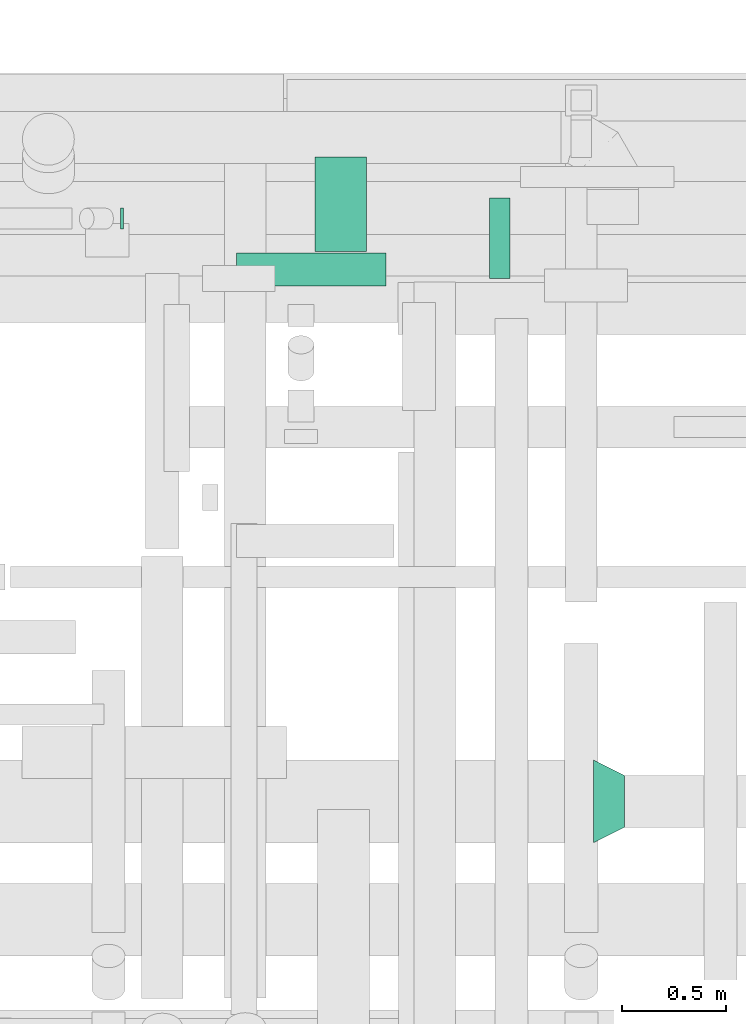
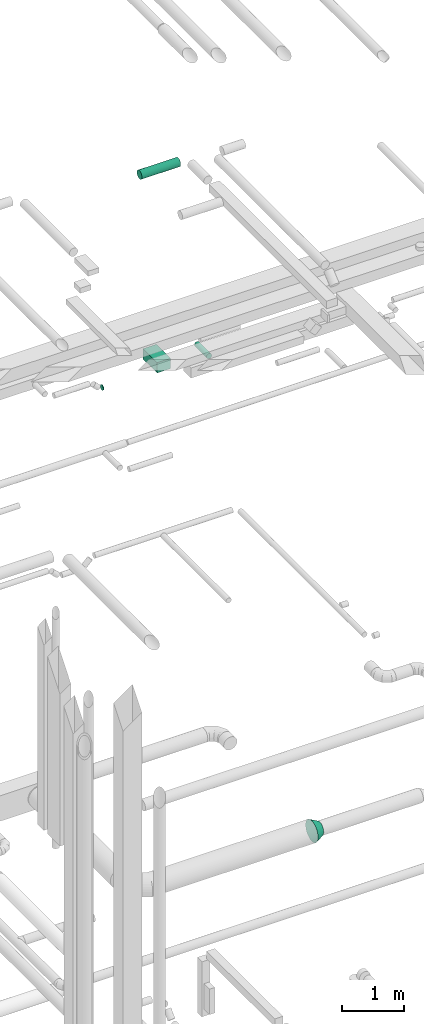
# One storey, part 290 of 337: 4 flow segments, 1 flow fitting.
"""IFC2X3 building model written with IfcOpenShell, lengths in millimetres."""

from ifc_helpers import new_model, entity, si_unit, converted_unit, derived_unit, direction, frame, origin, origin_2d_with_axis, place, context, subcontext, project, spatial, rectangle, circle, extrude, faceted_brep, source, transform, mapped, material, type_object, type_shapes, element, save


model = new_model("IFC2X3")

# Units and contexts
model_context = context("Model", 3, precision=0.01, world=origin(), true_north=direction((6.12303176911189e-17, 1.0)))
body_context = subcontext(model_context, "Body", "Model", "MODEL_VIEW")
ifc_project = project(units=[si_unit("LENGTHUNIT", "METRE", prefix="MILLI"), si_unit("AREAUNIT", "SQUARE_METRE"), si_unit("VOLUMEUNIT", "CUBIC_METRE"), converted_unit("PLANEANGLEUNIT", "DEGREE", entity("IfcRatioMeasure", 0.0174532925199433), si_unit("PLANEANGLEUNIT", "RADIAN"), dimensions=[0, 0, 0, 0, 0, 0, 0]), si_unit("MASSUNIT", "GRAM", prefix="KILO"), derived_unit("MASSDENSITYUNIT", [(si_unit("MASSUNIT", "GRAM", prefix="KILO"), 1), (si_unit("LENGTHUNIT", "METRE"), -3)]), derived_unit("MOMENTOFINERTIAUNIT", [(si_unit("LENGTHUNIT", "METRE"), 4)]), si_unit("TIMEUNIT", "SECOND"), si_unit("FREQUENCYUNIT", "HERTZ"), si_unit("THERMODYNAMICTEMPERATUREUNIT", "DEGREE_CELSIUS"), derived_unit("THERMALTRANSMITTANCEUNIT", [(si_unit("MASSUNIT", "GRAM", prefix="KILO"), 1), (si_unit("THERMODYNAMICTEMPERATUREUNIT", "KELVIN"), -1), (si_unit("TIMEUNIT", "SECOND"), -3)]), derived_unit("VOLUMETRICFLOWRATEUNIT", [(si_unit("LENGTHUNIT", "METRE"), 3), (si_unit("TIMEUNIT", "SECOND"), -1)]), derived_unit("MASSFLOWRATEUNIT", [(si_unit("MASSUNIT", "GRAM", prefix="KILO"), 1), (si_unit("TIMEUNIT", "SECOND"), -1)]), derived_unit("ROTATIONALFREQUENCYUNIT", [(si_unit("TIMEUNIT", "SECOND"), -1)]), si_unit("ELECTRICCURRENTUNIT", "AMPERE"), si_unit("ELECTRICVOLTAGEUNIT", "VOLT"), si_unit("POWERUNIT", "WATT"), si_unit("FORCEUNIT", "NEWTON", prefix="KILO"), si_unit("ILLUMINANCEUNIT", "LUX"), si_unit("LUMINOUSFLUXUNIT", "LUMEN"), si_unit("LUMINOUSINTENSITYUNIT", "CANDELA"), derived_unit("USERDEFINED", [(si_unit("MASSUNIT", "GRAM", prefix="KILO"), -1), (si_unit("LENGTHUNIT", "METRE"), -2), (si_unit("TIMEUNIT", "SECOND"), 3), (si_unit("LUMINOUSFLUXUNIT", "LUMEN"), 1)]), derived_unit("LINEARVELOCITYUNIT", [(si_unit("LENGTHUNIT", "METRE"), 1), (si_unit("TIMEUNIT", "SECOND"), -1)]), si_unit("PRESSUREUNIT", "PASCAL"), derived_unit("USERDEFINED", [(si_unit("LENGTHUNIT", "METRE"), -2), (si_unit("MASSUNIT", "GRAM", prefix="KILO"), 1), (si_unit("TIMEUNIT", "SECOND"), -2)]), derived_unit("LINEARFORCEUNIT", [(si_unit("MASSUNIT", "GRAM", prefix="KILO"), 1), (si_unit("LENGTHUNIT", "METRE"), 1), (si_unit("TIMEUNIT", "SECOND"), -2), (si_unit("LENGTHUNIT", "METRE"), -1)]), derived_unit("PLANARFORCEUNIT", [(si_unit("MASSUNIT", "GRAM", prefix="KILO"), 1), (si_unit("LENGTHUNIT", "METRE"), 1), (si_unit("TIMEUNIT", "SECOND"), -2), (si_unit("LENGTHUNIT", "METRE"), -2)])], contexts=[model_context])

# Site, building, storey
site_placement = place(None, origin())
site = spatial("IfcSite", under=ifc_project, at=site_placement, CompositionType="ELEMENT")
building_placement = place(site_placement, origin())
building = spatial("IfcBuilding", under=site, at=building_placement, CompositionType="ELEMENT")
storey_placement = place(building_placement, origin())
storey = spatial("IfcBuildingStorey", under=building, at=storey_placement, CompositionType="ELEMENT", Elevation=0.0)

# Flow segments
duct_segment_type_1 = type_object("IfcDuctSegmentType", PredefinedType="NOTDEFINED")
flow_segment_1_placement = place(storey_placement, frame((57179.84, 19247.07, 11300.0)))
element("IfcFlowSegment", 1, at=flow_segment_1_placement, inside=storey, type_object=duct_segment_type_1, context=body_context, shape_type="SweptSolid", body=[
    extrude(rectangle(XDim=453.988079999886, YDim=250.000000000004, at=origin_2d_with_axis()), frame((125.0, 226.99, 0.0), z_axis=(0.0, 0.0, 1.0), x_axis=(0.0, 1.0, 0.0)), (0.0, 0.0, 1.0), 200.000000000002),
])
duct_segment_type_2 = type_object("IfcDuctSegmentType", PredefinedType="NOTDEFINED")
flow_segment_2_placement = place(storey_placement, frame((56244.5, 19353.19, 11196.38)))
element("IfcFlowSegment", 2, at=flow_segment_2_placement, inside=storey, type_object=duct_segment_type_2, context=body_context, shape_type="SweptSolid", body=[
    extrude(circle(Radius=50.0, at=origin_2d_with_axis()), frame((0.0, 51.6, 51.6), z_axis=(1.0, 0.0, 0.0), x_axis=(0.0, -1.0, 0.0)), (0.0, 0.0, 1.0), 13.5786437626849),
])
flow_segment_3_placement = place(storey_placement, frame((56802.59, 19078.35, 15293.4)))
element("IfcFlowSegment", 3, at=flow_segment_3_placement, inside=storey, type_object=duct_segment_type_2, context=body_context, shape_type="SweptSolid", body=[
    extrude(circle(Radius=80.0, at=origin_2d_with_axis()), frame((0.0, 81.6, 81.6), z_axis=(1.0, 0.0, 0.0), x_axis=(0.0, 1.0, 0.0)), (0.0, 0.0, 1.0), 719.999999999975),
])
flow_segment_4_placement = place(storey_placement, frame((58019.22, 19117.07, 11348.4)))
element("IfcFlowSegment", 4, at=flow_segment_4_placement, inside=storey, type_object=duct_segment_type_2, context=body_context, shape_type="SweptSolid", body=[
    extrude(circle(Radius=50.0, at=origin_2d_with_axis()), frame((51.6, 0.0, 51.6), z_axis=(0.0, 1.0, 0.0), x_axis=(1.0, 0.0, 0.0)), (0.0, 0.0, 1.0), 387.71828396549),
])

# Flow fitting
ifc_material = material()
duct_fitting_type = type_object("IfcDuctFittingType", PredefinedType="NOTDEFINED", material=ifc_material)
shared_shape = source(origin(), body_context, "Body", "Brep", [
    faceted_brep([(150.0, 101.13, -73.47), (150.0, 118.88, -38.63), (150.0, 125.0, 0.0), (150.0, 118.88, 38.63), (150.0, 101.13, 73.47), (150.0, 73.47, 101.13), (150.0, 38.63, 118.88), (150.0, 0.0, 125.0), (150.0, -38.63, 118.88), (150.0, -73.47, 101.13), (150.0, -101.13, 73.47), (150.0, -118.88, 38.63), (150.0, -125.0, 0.0), (150.0, -118.88, -38.63), (150.0, -101.13, -73.47), (150.0, -73.47, -101.13), (150.0, -38.63, -118.88), (150.0, 0.0, -125.0), (150.0, 38.63, -118.88), (150.0, 73.47, -101.13), (0.0, -200.0, 0.0), (0.0, -194.99, 44.5), (0.0, -180.19, 86.78), (0.0, -156.37, 124.7), (0.0, -124.7, 156.37), (0.0, -86.78, 180.19), (0.0, -44.5, 194.99), (0.0, 0.0, 200.0), (0.0, 44.5, 194.99), (0.0, 86.78, 180.19), (0.0, 124.7, 156.37), (0.0, 156.37, 124.7), (0.0, 180.19, 86.78), (0.0, 194.99, 44.5), (0.0, 200.0, 0.0), (0.0, 194.99, -44.5), (0.0, 180.19, -86.78), (0.0, 156.37, -124.7), (0.0, 124.7, -156.37), (0.0, 86.78, -180.19), (0.0, 44.5, -194.99), (0.0, 0.0, -200.0), (0.0, -44.5, -194.99), (0.0, -86.78, -180.19), (0.0, -124.7, -156.37), (0.0, -156.37, -124.7), (0.0, -180.19, -86.78), (0.0, -194.99, -44.5)], [[[0, 1, 2, 3, 4, 5, 6, 7, 8, 9, 10, 11, 12, 13, 14, 15, 16, 17, 18, 19]], [[20, 21, 22, 23, 24, 25, 26, 27, 28, 29, 30, 31, 32, 33, 34, 35, 36, 37, 38, 39, 40, 41, 42, 43, 44, 45, 46, 47]], [[6, 5, 29]], [[7, 6, 28]], [[27, 7, 28]], [[29, 28, 6]], [[30, 29, 5]], [[5, 4, 31, 30]], [[32, 4, 3]], [[33, 3, 2]], [[32, 31, 4]], [[34, 33, 2]], [[32, 3, 33]], [[11, 10, 22]], [[12, 11, 21]], [[20, 12, 21]], [[22, 21, 11]], [[23, 22, 10]], [[10, 9, 24, 23]], [[25, 9, 8]], [[26, 8, 7]], [[25, 24, 9]], [[27, 26, 7]], [[25, 8, 26]], [[16, 15, 43]], [[17, 16, 42]], [[41, 17, 42]], [[43, 42, 16]], [[44, 43, 15]], [[15, 14, 45, 44]], [[46, 14, 13]], [[47, 13, 12]], [[46, 45, 14]], [[20, 47, 12]], [[46, 13, 47]], [[1, 0, 36]], [[2, 1, 35]], [[34, 2, 35]], [[36, 35, 1]], [[37, 36, 0]], [[0, 19, 38, 37]], [[39, 19, 18]], [[40, 18, 17]], [[39, 38, 19]], [[41, 40, 17]], [[39, 18, 40]]]),
])
type_shapes(duct_fitting_type, [shared_shape])
flow_fitting_placement = place(storey_placement, frame((58522.05, 16596.24, 3450.0)))
element("IfcFlowFitting", 5, at=flow_fitting_placement, inside=storey, type_object=duct_fitting_type, material=ifc_material, context=body_context, shape_type="MappedRepresentation", body=[
    mapped(shared_shape, transform((0.0, 0.0, 0.0), scale=1.0)),
])

save(model, "model.ifc")
